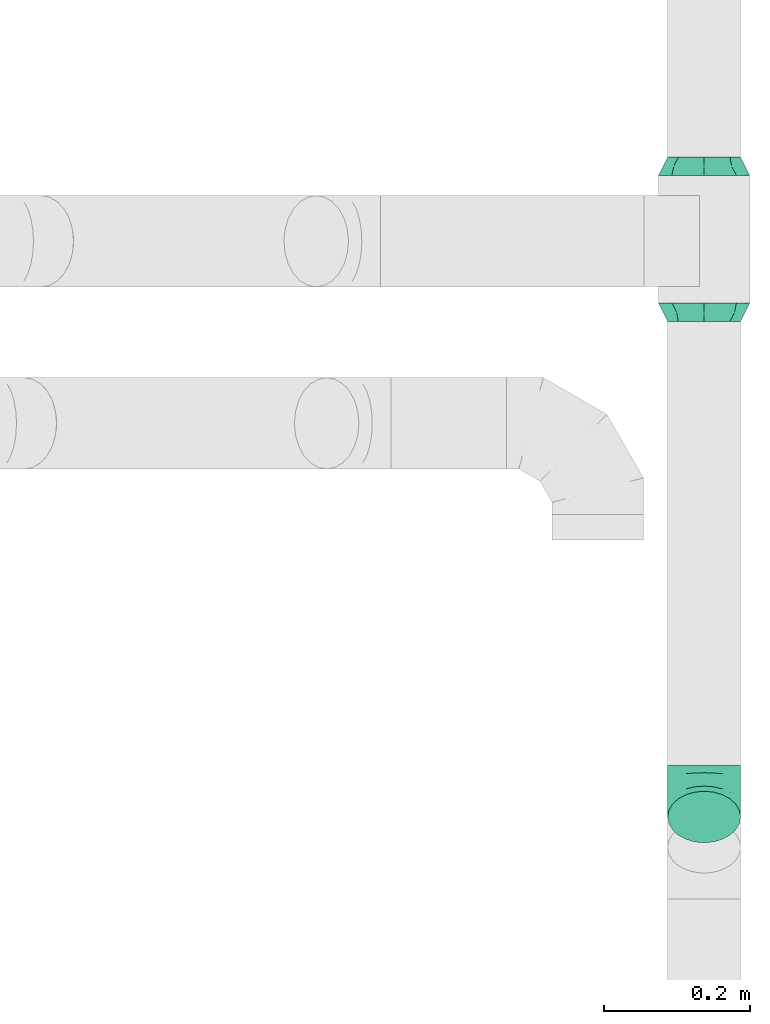
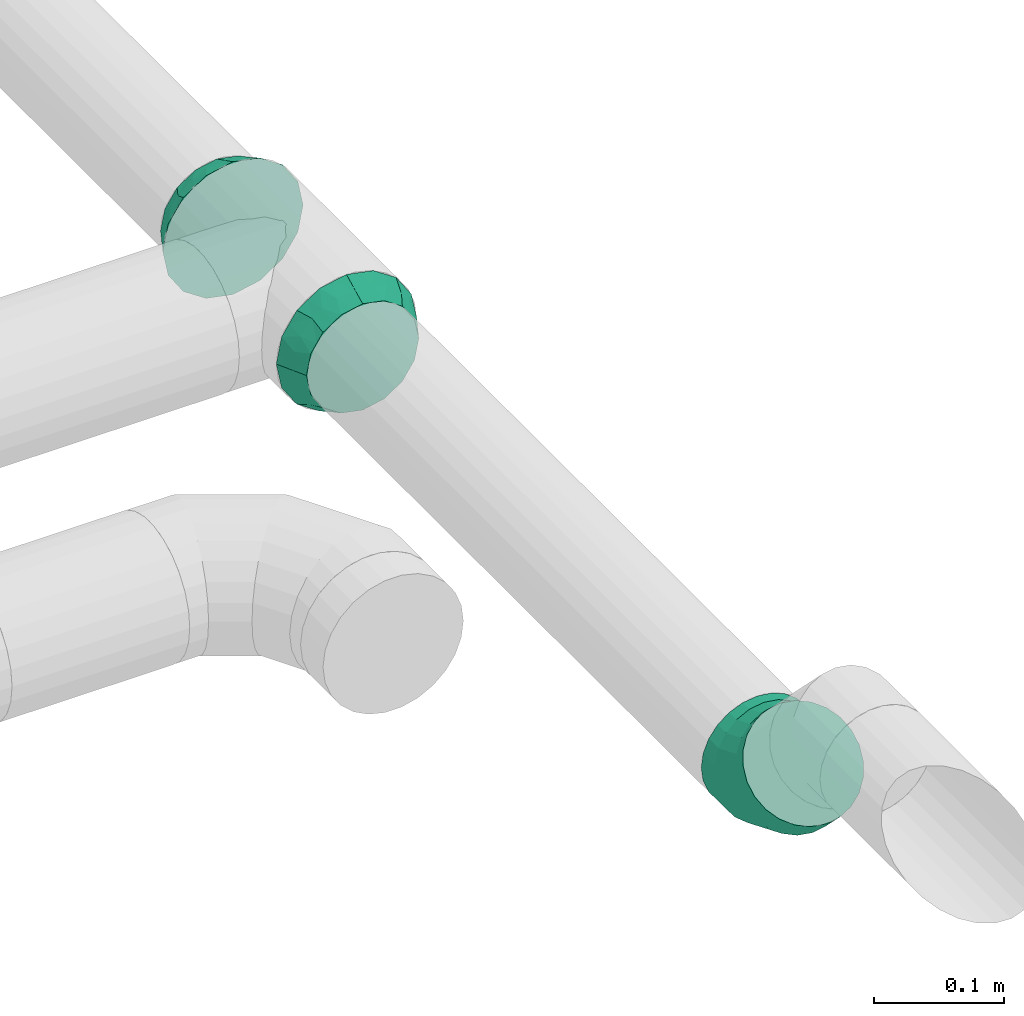
# One storey, part 59 of 60: 3 flow fittings.
"""IFC2X3 building model written with IfcOpenShell, lengths in millimetres."""

from ifc_helpers import new_model, entity, si_unit, converted_unit, derived_unit, direction, frame, origin, place, context, subcontext, project, spatial, faceted_brep, source, transform, mapped, material, type_object, type_shapes, element, save


model = new_model("IFC2X3")

# Units and contexts
model_context = context("Model", 3, precision=0.01, world=origin(), true_north=direction((6.12303176911189e-17, 1.0)))
body_context = subcontext(model_context, "Body", "Model", "MODEL_VIEW")
ifc_project = project(units=[si_unit("LENGTHUNIT", "METRE", prefix="MILLI"), si_unit("AREAUNIT", "SQUARE_METRE"), si_unit("VOLUMEUNIT", "CUBIC_METRE"), converted_unit("PLANEANGLEUNIT", "DEGREE", entity("IfcRatioMeasure", 0.0174532925199433), si_unit("PLANEANGLEUNIT", "RADIAN"), dimensions=[0, 0, 0, 0, 0, 0, 0]), si_unit("MASSUNIT", "GRAM", prefix="KILO"), derived_unit("MASSDENSITYUNIT", [(si_unit("MASSUNIT", "GRAM", prefix="KILO"), 1), (si_unit("LENGTHUNIT", "METRE"), -3)]), derived_unit("MOMENTOFINERTIAUNIT", [(si_unit("LENGTHUNIT", "METRE"), 4)]), si_unit("TIMEUNIT", "SECOND"), si_unit("FREQUENCYUNIT", "HERTZ"), si_unit("THERMODYNAMICTEMPERATUREUNIT", "DEGREE_CELSIUS"), derived_unit("THERMALTRANSMITTANCEUNIT", [(si_unit("MASSUNIT", "GRAM", prefix="KILO"), 1), (si_unit("THERMODYNAMICTEMPERATUREUNIT", "KELVIN"), -1), (si_unit("TIMEUNIT", "SECOND"), -3)]), derived_unit("VOLUMETRICFLOWRATEUNIT", [(si_unit("LENGTHUNIT", "METRE"), 3), (si_unit("TIMEUNIT", "SECOND"), -1)]), derived_unit("MASSFLOWRATEUNIT", [(si_unit("MASSUNIT", "GRAM", prefix="KILO"), 1), (si_unit("TIMEUNIT", "SECOND"), -1)]), derived_unit("ROTATIONALFREQUENCYUNIT", [(si_unit("TIMEUNIT", "SECOND"), -1)]), si_unit("ELECTRICCURRENTUNIT", "AMPERE"), si_unit("ELECTRICVOLTAGEUNIT", "VOLT"), si_unit("POWERUNIT", "WATT"), si_unit("FORCEUNIT", "NEWTON", prefix="KILO"), si_unit("ILLUMINANCEUNIT", "LUX"), si_unit("LUMINOUSFLUXUNIT", "LUMEN"), si_unit("LUMINOUSINTENSITYUNIT", "CANDELA"), derived_unit("USERDEFINED", [(si_unit("MASSUNIT", "GRAM", prefix="KILO"), -1), (si_unit("LENGTHUNIT", "METRE"), -2), (si_unit("TIMEUNIT", "SECOND"), 3), (si_unit("LUMINOUSFLUXUNIT", "LUMEN"), 1)]), derived_unit("LINEARVELOCITYUNIT", [(si_unit("LENGTHUNIT", "METRE"), 1), (si_unit("TIMEUNIT", "SECOND"), -1)]), si_unit("PRESSUREUNIT", "PASCAL"), derived_unit("USERDEFINED", [(si_unit("LENGTHUNIT", "METRE"), -2), (si_unit("MASSUNIT", "GRAM", prefix="KILO"), 1), (si_unit("TIMEUNIT", "SECOND"), -2)]), derived_unit("LINEARFORCEUNIT", [(si_unit("MASSUNIT", "GRAM", prefix="KILO"), 1), (si_unit("LENGTHUNIT", "METRE"), 1), (si_unit("TIMEUNIT", "SECOND"), -2), (si_unit("LENGTHUNIT", "METRE"), -1)]), derived_unit("PLANARFORCEUNIT", [(si_unit("MASSUNIT", "GRAM", prefix="KILO"), 1), (si_unit("LENGTHUNIT", "METRE"), 1), (si_unit("TIMEUNIT", "SECOND"), -2), (si_unit("LENGTHUNIT", "METRE"), -2)])], contexts=[model_context])

# Site, building, storey
site_placement = place(None, origin())
site = spatial("IfcSite", under=ifc_project, at=site_placement, CompositionType="ELEMENT")
building_placement = place(site_placement, origin())
building = spatial("IfcBuilding", under=site, at=building_placement, CompositionType="ELEMENT")
storey_placement = place(building_placement, frame((0.0, 0.0, 19800.0)))
storey = spatial("IfcBuildingStorey", under=building, at=storey_placement, CompositionType="ELEMENT", Elevation=19800.0)

# Flow fittings
ifc_material = material()
duct_fitting_type_1 = type_object("IfcDuctFittingType", PredefinedType="NOTDEFINED", material=ifc_material)
shared_shape_1 = source(origin(), body_context, "Body", "Brep", [
    faceted_brep([(25.0, -19.13, -46.21), (25.0, -9.57, -48.11), (25.0, 0.0, -50.01), (25.0, 8.4, -48.34), (25.0, 19.13, -46.21), (25.0, 27.24, -40.79), (25.0, 35.36, -35.37), (25.0, 40.77, -27.26), (25.0, 46.19, -19.15), (25.0, 48.1, -9.58), (25.0, 50.0, -0.01), (25.0, 48.33, 8.39), (25.0, 46.19, 19.12), (25.0, 40.77, 27.23), (25.0, 35.36, 35.34), (25.0, 27.24, 40.76), (25.0, 19.13, 46.18), (25.0, 9.57, 48.08), (25.0, 0.0, 49.99), (25.0, -8.4, 48.32), (25.0, -19.13, 46.18), (25.0, -27.24, 40.76), (25.0, -35.36, 35.34), (25.0, -40.77, 27.23), (25.0, -46.19, 19.12), (25.0, -48.1, 9.55), (25.0, -50.0, -0.01), (25.0, -48.33, -8.41), (25.0, -46.19, -19.15), (25.0, -40.77, -27.26), (25.0, -35.36, -35.37), (25.0, -27.24, -40.79), (0.0, -44.19, -44.19), (0.0, -50.97, -34.06), (0.0, -57.74, -23.92), (0.0, -60.12, -11.96), (0.0, -62.5, 0.0), (0.0, -60.41, 10.5), (0.0, -57.74, 23.92), (0.0, -50.97, 34.06), (0.0, -44.19, 44.19), (0.0, -34.06, 50.97), (0.0, -23.92, 57.74), (0.0, -11.96, 60.12), (0.0, 0.0, 62.5), (0.0, 10.5, 60.41), (0.0, 23.92, 57.74), (0.0, 34.06, 50.97), (0.0, 44.19, 44.19), (0.0, 50.97, 34.06), (0.0, 57.74, 23.92), (0.0, 60.12, 11.96), (0.0, 62.5, 0.0), (0.0, 60.41, -10.5), (0.0, 57.74, -23.92), (0.0, 50.97, -34.06), (0.0, 44.19, -44.19), (0.0, 34.06, -50.97), (0.0, 23.92, -57.74), (0.0, 11.96, -60.12), (0.0, 0.0, -62.5), (0.0, -10.5, -60.41), (0.0, -23.92, -57.74), (0.0, -34.06, -50.97), (12.5, 48.39, 28.68), (12.5, 53.83, 16.32), (13.89, 55.56, -0.01), (11.11, 56.94, -0.01), (12.5, 41.71, 37.73), (12.5, 28.69, 48.38), (12.5, 16.33, 53.82), (11.11, 0.0, 56.94), (13.89, 0.0, 55.55), (12.5, -28.69, 48.38), (12.5, -16.33, 53.82), (12.5, -37.74, 41.71), (12.5, -48.39, 28.68), (12.5, -53.83, 16.32), (11.11, -56.94, -0.01), (13.89, -55.56, -0.01), (12.5, -48.39, -28.69), (12.5, -53.83, -16.33), (12.5, -41.71, -37.74), (12.5, -28.69, -48.39), (12.5, -16.33, -53.83), (11.11, 0.0, -56.95), (13.89, 0.0, -55.56), (12.5, 28.69, -48.39), (12.5, 16.33, -53.83), (12.5, 37.74, -41.72), (12.5, 48.39, -28.69), (12.5, 53.83, -16.33)], [[[0, 1, 2, 3, 4, 5, 6, 7, 8, 9, 10, 11, 12, 13, 14, 15, 16, 17, 18, 19, 20, 21, 22, 23, 24, 25, 26, 27, 28, 29, 30, 31]], [[32, 33, 34, 35, 36, 37, 38, 39, 40, 41, 42, 43, 44, 45, 46, 47, 48, 49, 50, 51, 52, 53, 54, 55, 56, 57, 58, 59, 60, 61, 62, 63]], [[64, 65, 50]], [[51, 66, 67, 52]], [[11, 10, 66]], [[65, 11, 66]], [[65, 51, 50]], [[12, 65, 64]], [[14, 13, 68]], [[64, 50, 49]], [[69, 70, 16]], [[11, 65, 12]], [[70, 69, 46]], [[70, 17, 16]], [[71, 70, 45]], [[68, 69, 15]], [[68, 49, 48]], [[66, 51, 65]], [[13, 12, 64]], [[68, 13, 64]], [[17, 71, 72, 18]], [[45, 44, 71]], [[71, 17, 70]], [[45, 70, 46]], [[69, 16, 15]], [[68, 47, 69]], [[49, 68, 64]], [[68, 15, 14]], [[47, 46, 69]], [[68, 48, 47]], [[73, 74, 42]], [[43, 72, 71, 44]], [[19, 18, 72]], [[74, 19, 72]], [[74, 43, 42]], [[20, 74, 73]], [[22, 21, 75]], [[73, 42, 41]], [[76, 77, 24]], [[19, 74, 20]], [[77, 76, 38]], [[77, 25, 24]], [[78, 77, 37]], [[75, 76, 23]], [[75, 41, 40]], [[72, 43, 74]], [[21, 20, 73]], [[75, 21, 73]], [[25, 78, 79, 26]], [[37, 36, 78]], [[78, 25, 77]], [[37, 77, 38]], [[76, 24, 23]], [[75, 39, 76]], [[41, 75, 73]], [[75, 23, 22]], [[39, 38, 76]], [[75, 40, 39]], [[80, 81, 34]], [[35, 79, 78, 36]], [[27, 26, 79]], [[81, 27, 79]], [[81, 35, 34]], [[28, 81, 80]], [[30, 29, 82]], [[80, 34, 33]], [[83, 84, 0]], [[27, 81, 28]], [[84, 83, 62]], [[84, 1, 0]], [[85, 84, 61]], [[82, 83, 31]], [[82, 33, 32]], [[79, 35, 81]], [[29, 28, 80]], [[82, 29, 80]], [[1, 85, 86, 2]], [[61, 60, 85]], [[85, 1, 84]], [[61, 84, 62]], [[83, 0, 31]], [[82, 63, 83]], [[33, 82, 80]], [[82, 31, 30]], [[63, 62, 83]], [[82, 32, 63]], [[87, 88, 58]], [[59, 86, 85, 60]], [[3, 2, 86]], [[88, 3, 86]], [[88, 59, 58]], [[4, 88, 87]], [[6, 5, 89]], [[87, 58, 57]], [[90, 91, 8]], [[3, 88, 4]], [[91, 90, 54]], [[91, 9, 8]], [[67, 91, 53]], [[89, 90, 7]], [[89, 57, 56]], [[86, 59, 88]], [[5, 4, 87]], [[89, 5, 87]], [[9, 67, 66, 10]], [[53, 52, 67]], [[67, 9, 91]], [[53, 91, 54]], [[90, 8, 7]], [[89, 55, 90]], [[57, 89, 87]], [[89, 7, 6]], [[55, 54, 90]], [[89, 56, 55]]]),
])
type_shapes(duct_fitting_type_1, [shared_shape_1])
flow_fitting_1_placement = place(storey_placement, frame((72241.06, 10165.73, 3099.91), z_axis=(0.0, 0.000140295384152198, 0.999999990158603), x_axis=(0.0, 0.999999990158603, -0.000140295384152198)))
element("IfcFlowFitting", 1, at=flow_fitting_1_placement, inside=storey, type_object=duct_fitting_type_1, material=ifc_material, context=body_context, shape_type="MappedRepresentation", body=[
    mapped(shared_shape_1, transform((0.0, 0.0, 0.0), scale=1.0)),
])
duct_fitting_type_2 = type_object("IfcDuctFittingType", PredefinedType="NOTDEFINED", material=ifc_material)
shared_shape_2 = source(origin(), body_context, "Body", "Brep", [
    faceted_brep([(-41.42, 0.0, -50.0), (-41.42, -12.94, -48.3), (-41.42, -25.0, -43.3), (-41.42, -35.36, -35.36), (-41.42, -43.3, -25.0), (-41.42, -48.3, -12.94), (-41.42, -50.0, 0.0), (-41.42, -48.3, 12.94), (-41.42, -43.3, 25.0), (-41.42, -35.36, 35.36), (-41.42, -25.0, 43.3), (-41.42, -12.94, 48.3), (-41.42, 0.0, 50.0), (-41.42, 12.94, 48.3), (-41.42, 25.0, 43.3), (-41.42, 35.36, 35.36), (-41.42, 43.3, 25.0), (-41.42, 48.3, 12.94), (-41.42, 50.0, 0.0), (-41.42, 48.3, -12.94), (-41.42, 43.3, -25.0), (-41.42, 35.36, -35.36), (-41.42, 25.0, -43.3), (-41.42, 12.94, -48.3), (-24.1, 12.94, 48.3), (-26.5, 25.0, 43.3), (-21.53, 0.0, 50.0), (-28.56, 35.36, 35.36), (-31.14, 48.3, 12.94), (-31.48, 50.0, 0.0), (-30.14, 43.3, 25.0), (-30.14, 43.3, -25.0), (-28.56, 35.36, -35.36), (-31.14, 48.3, -12.94), (-24.1, 12.94, -48.3), (-21.53, 0.0, -50.0), (-26.5, 25.0, -43.3), (-18.96, -12.94, -48.3), (-16.56, -25.0, -43.3), (-14.5, -35.36, -35.36), (-12.92, -43.3, -25.0), (-11.92, -48.3, -12.94), (-11.58, -50.0, 0.0), (-11.92, -48.3, 12.94), (-12.92, -43.3, 25.0), (-14.5, -35.36, 35.36), (-16.56, -25.0, 43.3), (-18.96, -12.94, 48.3), (7.89, 26.2, 48.3), (1.06, 36.42, 43.3), (15.22, 15.22, 50.0), (-4.8, 45.2, 35.36), (-12.13, 56.17, 12.94), (-13.1, 57.61, 0.0), (-9.3, 51.93, 25.0), (-9.3, 51.93, -25.0), (-4.8, 45.2, -35.36), (-12.13, 56.17, -12.94), (7.89, 26.2, -48.3), (15.22, 15.22, -50.0), (1.06, 36.42, -43.3), (22.55, 4.25, -48.3), (29.39, -5.97, -43.3), (35.25, -14.75, -35.36), (39.75, -21.48, -25.0), (42.58, -25.72, -12.94), (43.55, -27.16, 0.0), (42.58, -25.72, 12.94), (39.75, -21.48, 25.0), (35.25, -14.75, 35.36), (29.39, -5.97, 43.3), (22.55, 4.25, 48.3), (29.29, 29.29, 50.0), (20.14, 38.44, 48.3), (11.61, 46.97, 43.3), (4.29, 54.29, 35.36), (-1.33, 59.91, 25.0), (-4.86, 63.44, 12.94), (-6.07, 64.64, 0.0), (-4.86, 63.44, -12.94), (-1.33, 59.91, -25.0), (4.29, 54.29, -35.36), (11.61, 46.97, -43.3), (20.14, 38.44, -48.3), (29.29, 29.29, -50.0), (38.44, 20.14, -48.3), (46.97, 11.61, -43.3), (54.29, 4.29, -35.36), (59.91, -1.33, -25.0), (63.44, -4.86, -12.94), (64.64, -6.07, 0.0), (63.44, -4.86, 12.94), (59.91, -1.33, 25.0), (54.29, 4.29, 35.36), (46.97, 11.61, 43.3), (38.44, 20.14, 48.3)], [[[0, 1, 2, 3, 4, 5, 6, 7, 8, 9, 10, 11, 12, 13, 14, 15, 16, 17, 18, 19, 20, 21, 22, 23]], [[24, 25, 14, 13]], [[26, 24, 13, 12]], [[14, 25, 27, 15]], [[28, 29, 18, 17]], [[30, 28, 17, 16]], [[15, 27, 30, 16]], [[20, 31, 32, 21]], [[33, 31, 20, 19]], [[18, 29, 33, 19]], [[34, 35, 0, 23]], [[36, 34, 23, 22]], [[32, 36, 22, 21]], [[2, 1, 37, 38]], [[3, 2, 38, 39]], [[0, 35, 37, 1]], [[5, 4, 40, 41]], [[6, 5, 41, 42]], [[39, 40, 4, 3]], [[6, 42, 43, 7]], [[7, 43, 44, 8]], [[8, 44, 45, 9]], [[10, 46, 47, 11]], [[11, 47, 26, 12]], [[9, 45, 46, 10]], [[48, 49, 25, 24]], [[50, 48, 24, 26]], [[25, 49, 51, 27]], [[52, 53, 29, 28]], [[54, 52, 28, 30]], [[30, 27, 51, 54]], [[55, 56, 32, 31]], [[57, 55, 31, 33]], [[53, 57, 33, 29]], [[58, 59, 35, 34]], [[60, 58, 34, 36]], [[36, 32, 56, 60]], [[35, 59, 61, 37]], [[38, 37, 61, 62]], [[39, 38, 62, 63]], [[41, 40, 64, 65]], [[42, 41, 65, 66]], [[63, 64, 40, 39]], [[43, 42, 66, 67]], [[44, 43, 67, 68]], [[68, 69, 45, 44]], [[46, 45, 69, 70]], [[47, 46, 70, 71]], [[26, 47, 71, 50]], [[48, 50, 72, 73]], [[49, 48, 73, 74]], [[51, 49, 74, 75]], [[52, 54, 76, 77]], [[53, 52, 77, 78]], [[51, 75, 76, 54]], [[53, 78, 79, 57]], [[57, 79, 80, 55]], [[55, 80, 81, 56]], [[60, 82, 83, 58]], [[58, 83, 84, 59]], [[60, 56, 81, 82]], [[59, 84, 85, 61]], [[61, 85, 86, 62]], [[62, 86, 87, 63]], [[64, 88, 89, 65]], [[65, 89, 90, 66]], [[63, 87, 88, 64]], [[67, 66, 90, 91]], [[68, 67, 91, 92]], [[69, 68, 92, 93]], [[71, 70, 94, 95]], [[50, 71, 95, 72]], [[93, 94, 70, 69]], [[83, 82, 81, 80, 79, 78, 77, 76, 75, 74, 73, 72, 95, 94, 93, 92, 91, 90, 89, 88, 87, 86, 85, 84]]]),
])
type_shapes(duct_fitting_type_2, [shared_shape_2])
flow_fitting_2_placement = place(storey_placement, frame((72241.06, 9315.73, 3100.0), z_axis=(1.0, 0.0, 0.0), x_axis=(0.0, 0.707106781186372, -0.707106781186723)))
element("IfcFlowFitting", 2, at=flow_fitting_2_placement, inside=storey, type_object=duct_fitting_type_2, material=ifc_material, context=body_context, shape_type="MappedRepresentation", body=[
    mapped(shared_shape_2, transform((0.0, 0.0, 0.0), scale=1.0)),
])
duct_fitting_type_3 = type_object("IfcDuctFittingType", PredefinedType="NOTDEFINED", material=ifc_material)
shared_shape_3 = source(origin(), body_context, "Body", "Brep", [
    faceted_brep([(25.0, -19.13, -46.22), (25.0, -9.57, -48.13), (25.0, 0.0, -50.03), (25.0, 8.4, -48.36), (25.0, 19.13, -46.22), (25.0, 27.24, -40.8), (25.0, 35.36, -35.39), (25.0, 40.77, -27.27), (25.0, 46.19, -19.16), (25.0, 48.1, -9.6), (25.0, 50.0, -0.03), (25.0, 48.33, 8.37), (25.0, 46.19, 19.1), (25.0, 40.77, 27.21), (25.0, 35.36, 35.33), (25.0, 27.24, 40.74), (25.0, 19.13, 46.16), (25.0, 9.57, 48.07), (25.0, 0.0, 49.97), (25.0, -8.4, 48.3), (25.0, -19.13, 46.16), (25.0, -27.24, 40.74), (25.0, -35.36, 35.33), (25.0, -40.77, 27.21), (25.0, -46.19, 19.1), (25.0, -48.1, 9.54), (25.0, -50.0, -0.03), (25.0, -48.33, -8.43), (25.0, -46.19, -19.16), (25.0, -40.77, -27.27), (25.0, -35.36, -35.39), (25.0, -27.24, -40.8), (0.0, -44.19, -44.19), (0.0, -50.97, -34.06), (0.0, -57.74, -23.92), (0.0, -60.12, -11.96), (0.0, -62.5, 0.0), (0.0, -60.41, 10.5), (0.0, -57.74, 23.92), (0.0, -50.97, 34.06), (0.0, -44.19, 44.19), (0.0, -34.06, 50.97), (0.0, -23.92, 57.74), (0.0, -11.96, 60.12), (0.0, 0.0, 62.5), (0.0, 10.5, 60.41), (0.0, 23.92, 57.74), (0.0, 34.06, 50.97), (0.0, 44.19, 44.19), (0.0, 50.97, 34.06), (0.0, 57.74, 23.92), (0.0, 60.12, 11.96), (0.0, 62.5, 0.0), (0.0, 60.41, -10.5), (0.0, 57.74, -23.92), (0.0, 50.97, -34.06), (0.0, 44.19, -44.19), (0.0, 34.06, -50.97), (0.0, 23.92, -57.74), (0.0, 11.96, -60.12), (0.0, 0.0, -62.5), (0.0, -10.5, -60.41), (0.0, -23.92, -57.74), (0.0, -34.06, -50.97), (12.5, 48.39, 28.67), (12.5, 53.83, 16.31), (13.89, 55.56, -0.02), (11.11, 56.94, -0.01), (12.5, 41.71, 37.72), (12.5, 28.69, 48.37), (12.5, 16.33, 53.81), (11.11, 0.0, 56.93), (13.89, 0.0, 55.54), (12.5, -28.69, 48.37), (12.5, -16.33, 53.81), (12.5, -37.74, 41.7), (12.5, -48.39, 28.67), (12.5, -53.83, 16.31), (11.11, -56.94, -0.01), (13.89, -55.56, -0.02), (12.5, -48.39, -28.7), (12.5, -53.83, -16.34), (12.5, -41.71, -37.75), (12.5, -28.69, -48.4), (12.5, -16.33, -53.84), (11.11, 0.0, -56.96), (13.89, 0.0, -55.57), (12.5, 28.69, -48.4), (12.5, 16.33, -53.84), (12.5, 37.74, -41.73), (12.5, 48.39, -28.7), (12.5, 53.83, -16.34)], [[[0, 1, 2, 3, 4, 5, 6, 7, 8, 9, 10, 11, 12, 13, 14, 15, 16, 17, 18, 19, 20, 21, 22, 23, 24, 25, 26, 27, 28, 29, 30, 31]], [[32, 33, 34, 35, 36, 37, 38, 39, 40, 41, 42, 43, 44, 45, 46, 47, 48, 49, 50, 51, 52, 53, 54, 55, 56, 57, 58, 59, 60, 61, 62, 63]], [[64, 65, 50]], [[51, 66, 67, 52]], [[11, 10, 66]], [[65, 11, 66]], [[65, 51, 50]], [[12, 65, 64]], [[14, 13, 68]], [[64, 50, 49]], [[69, 70, 16]], [[11, 65, 12]], [[70, 69, 46]], [[70, 17, 16]], [[71, 70, 45]], [[68, 69, 15]], [[68, 49, 48]], [[66, 51, 65]], [[13, 12, 64]], [[68, 13, 64]], [[17, 71, 72, 18]], [[45, 44, 71]], [[71, 17, 70]], [[45, 70, 46]], [[69, 16, 15]], [[68, 47, 69]], [[49, 68, 64]], [[68, 15, 14]], [[47, 46, 69]], [[68, 48, 47]], [[73, 74, 42]], [[43, 72, 71, 44]], [[19, 18, 72]], [[74, 19, 72]], [[74, 43, 42]], [[20, 74, 73]], [[22, 21, 75]], [[73, 42, 41]], [[76, 77, 24]], [[19, 74, 20]], [[77, 76, 38]], [[77, 25, 24]], [[78, 77, 37]], [[75, 76, 23]], [[75, 41, 40]], [[72, 43, 74]], [[21, 20, 73]], [[75, 21, 73]], [[25, 78, 79, 26]], [[37, 36, 78]], [[78, 25, 77]], [[37, 77, 38]], [[76, 24, 23]], [[75, 39, 76]], [[41, 75, 73]], [[75, 23, 22]], [[39, 38, 76]], [[75, 40, 39]], [[80, 81, 34]], [[35, 79, 78, 36]], [[27, 26, 79]], [[81, 27, 79]], [[81, 35, 34]], [[28, 81, 80]], [[30, 29, 82]], [[80, 34, 33]], [[83, 84, 0]], [[27, 81, 28]], [[84, 83, 62]], [[84, 1, 0]], [[85, 84, 61]], [[82, 83, 31]], [[82, 33, 32]], [[79, 35, 81]], [[29, 28, 80]], [[82, 29, 80]], [[1, 85, 86, 2]], [[61, 60, 85]], [[85, 1, 84]], [[61, 84, 62]], [[83, 0, 31]], [[82, 63, 83]], [[33, 82, 80]], [[82, 31, 30]], [[63, 62, 83]], [[82, 32, 63]], [[87, 88, 58]], [[59, 86, 85, 60]], [[3, 2, 86]], [[88, 3, 86]], [[88, 59, 58]], [[4, 88, 87]], [[6, 5, 89]], [[87, 58, 57]], [[90, 91, 8]], [[3, 88, 4]], [[91, 90, 54]], [[91, 9, 8]], [[67, 91, 53]], [[89, 90, 7]], [[89, 57, 56]], [[86, 59, 88]], [[5, 4, 87]], [[89, 5, 87]], [[9, 67, 66, 10]], [[53, 52, 67]], [[67, 9, 91]], [[53, 91, 54]], [[90, 8, 7]], [[89, 55, 90]], [[57, 89, 87]], [[89, 7, 6]], [[55, 54, 90]], [[89, 56, 55]]]),
])
type_shapes(duct_fitting_type_3, [shared_shape_3])
flow_fitting_3_placement = place(storey_placement, frame((72241.06, 9990.73, 3100.04), z_axis=(0.0, 0.000140295384152198, 0.999999990158603), x_axis=(0.0, -0.999999990158603, 0.000140295384152198)))
element("IfcFlowFitting", 3, at=flow_fitting_3_placement, inside=storey, type_object=duct_fitting_type_3, material=ifc_material, context=body_context, shape_type="MappedRepresentation", body=[
    mapped(shared_shape_3, transform((0.0, 0.0, 0.0), scale=1.0)),
])

save(model, "model.ifc")
